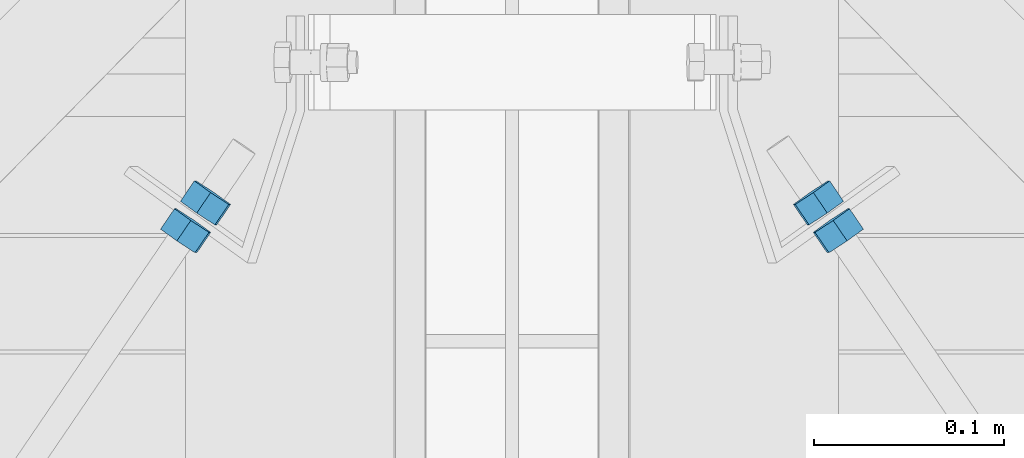
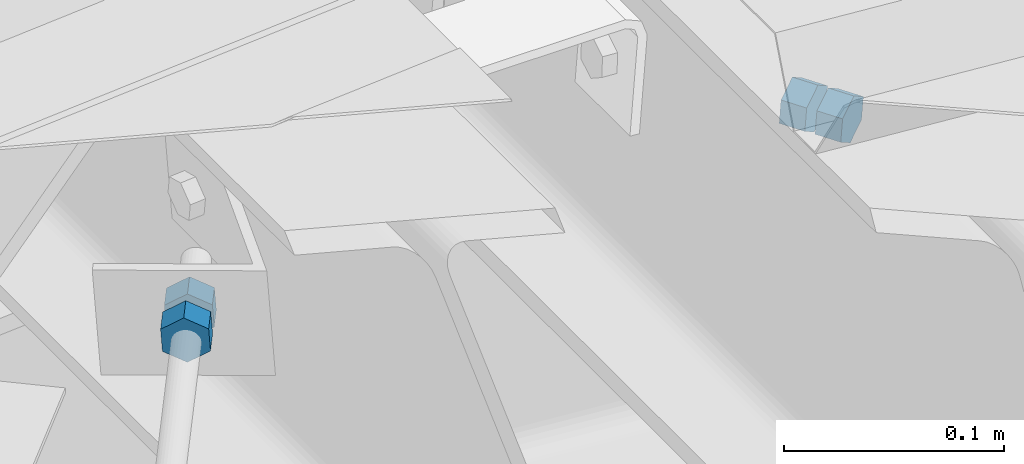
# One storey, part 26 of 70: 4 beams, 4 elements without a shape of their own.
"""IFC2X3 building model written with IfcOpenShell, lengths in millimetres."""

from ifc_helpers import new_model, si_unit, frame, origin_with_axes, place, context, subcontext, project, spatial, polyline, outline, extrude, material, type_object, element, aggregate, save


model = new_model("IFC2X3")

# Units and contexts
model_context = context("Model", 3, precision=1e-05, world=origin_with_axes())
body_context = subcontext(model_context, "Body", "Model", "MODEL_VIEW")
ifc_project = project(units=[si_unit("LENGTHUNIT", "METRE", prefix="MILLI"), si_unit("AREAUNIT", "SQUARE_METRE"), si_unit("VOLUMEUNIT", "CUBIC_METRE"), si_unit("MASSUNIT", "GRAM", prefix="KILO"), si_unit("TIMEUNIT", "SECOND"), si_unit("PLANEANGLEUNIT", "RADIAN"), si_unit("SOLIDANGLEUNIT", "STERADIAN"), si_unit("THERMODYNAMICTEMPERATUREUNIT", "DEGREE_CELSIUS"), si_unit("LUMINOUSINTENSITYUNIT", "LUMEN")], contexts=[model_context])

# Site, building, storey
site_placement = place(None, origin_with_axes())
site = spatial("IfcSite", under=ifc_project, at=site_placement, CompositionType="ELEMENT")
building_placement = place(site_placement, origin_with_axes())
building = spatial("IfcBuilding", under=site, at=building_placement, Name="Undefined", CompositionType="ELEMENT")
storey_placement = place(building_placement, origin_with_axes())
storey = spatial("IfcBuildingStorey", under=building, at=storey_placement, Name="Undefined", CompositionType="ELEMENT", Elevation=0.0)

# Assembly, beam
assembly_1_placement = place(storey_placement, origin_with_axes())
assembly_1 = element("IfcElementAssembly", 1, at=assembly_1_placement, inside=storey, Name="Steel Assembly", AssemblyPlace="NOTDEFINED", PredefinedType="RIGID_FRAME")
ifc_material = material(Name="STEEL/S235JR")
beam_type = type_object("IfcBeamType", Name="M14", PredefinedType="NOTDEFINED")
beam_1_placement = place(assembly_1_placement, frame((6667.89591440817, 11763.4629953896, 5197.40989395115), z_axis=(-0.823334618986936, -0.564011508365624, 0.0633334319989954), x_axis=(0.562350226933823, -0.825766911902794, -0.0432577099948882)))
beam_1 = element("IfcBeam", 2, at=beam_1_placement, type_object=beam_type, material=ifc_material, Name="M14", ObjectType="M14", context=body_context, shape_type="SweptSolid", body=[
    extrude(outline(polyline([(12.7045926734972, 1.09139364212751e-11), (6.35229633673589, -11.002499999985), (-6.352296336775, -11.0024999999832), (-12.7045926735282, 1.36424205265939e-11), (-6.35229633676863, 11.0025000000087), (6.35229633674408, 11.0025000000069), (12.7045926734972, 1.09139364212751e-11)])), frame((13.0000000000422, -9.09404496152177e-13, 4.28476698567782e-16), z_axis=(-1.0, 0.0, 0.0), x_axis=(0.0, -1.0, 0.0)), (0.0, 0.0, 1.0), 13.0),
])
aggregate(assembly_1, [beam_1])

assembly_2_placement = place(storey_placement, origin_with_axes())
assembly_2 = element("IfcElementAssembly", 3, at=assembly_2_placement, inside=storey, Name="Steel Assembly", AssemblyPlace="NOTDEFINED", PredefinedType="RIGID_FRAME")
beam_2_placement = place(assembly_2_placement, frame((6657.46998747971, 11778.1141677896, 5198.21188833059), z_axis=(-0.823334618986936, -0.564011508365624, 0.0633334319989954), x_axis=(0.562350226933823, -0.825766911902794, -0.0432577099948882)))
beam_2 = element("IfcBeam", 4, at=beam_2_placement, type_object=beam_type, material=ifc_material, Name="M14", ObjectType="M14", context=body_context, shape_type="SweptSolid", body=[
    extrude(outline(polyline([(12.7045926734972, 1.09139364212751e-11), (6.35229633673589, -11.002499999985), (-6.352296336775, -11.0024999999832), (-12.7045926735282, 1.36424205265939e-11), (-6.35229633676863, 11.0025000000087), (6.35229633674408, 11.0025000000069), (12.7045926734972, 1.09139364212751e-11)])), frame((13.0000000000422, -9.09404496152177e-13, 4.28476698567782e-16), z_axis=(-1.0, 0.0, 0.0), x_axis=(0.0, -1.0, 0.0)), (0.0, 0.0, 1.0), 13.0),
])
aggregate(assembly_2, [beam_2])

assembly_3_placement = place(storey_placement, origin_with_axes())
assembly_3 = element("IfcElementAssembly", 5, at=assembly_3_placement, inside=storey, Name="Steel Assembly", AssemblyPlace="NOTDEFINED", PredefinedType="RIGID_FRAME")
beam_3_placement = place(assembly_3_placement, frame((6332.10408560018, 11763.4629953895, 5197.40989395091), z_axis=(0.823334618986981, -0.564011508365557, 0.063333431998999), x_axis=(-0.5623502269338, -0.825766911902807, -0.0432577099949295)))
beam_3 = element("IfcBeam", 6, at=beam_3_placement, type_object=beam_type, material=ifc_material, Name="M14", ObjectType="M14", context=body_context, shape_type="SweptSolid", body=[
    extrude(outline(polyline([(12.7045926734972, 1.09139364212751e-11), (6.35229633673589, -11.002499999985), (-6.352296336775, -11.0024999999832), (-12.7045926735282, 1.36424205265939e-11), (-6.35229633676863, 11.0025000000087), (6.35229633674408, 11.0025000000069), (12.7045926734972, 1.09139364212751e-11)])), frame((13.0000000000422, -9.09404496152177e-13, 4.28476698567782e-16), z_axis=(-1.0, 0.0, 0.0), x_axis=(0.0, -1.0, 0.0)), (0.0, 0.0, 1.0), 13.0),
])
aggregate(assembly_3, [beam_3])

assembly_4_placement = place(storey_placement, origin_with_axes())
assembly_4 = element("IfcElementAssembly", 7, at=assembly_4_placement, inside=storey, Name="Steel Assembly", AssemblyPlace="NOTDEFINED", PredefinedType="RIGID_FRAME")
beam_4_placement = place(assembly_4_placement, frame((6342.53001252864, 11778.1141677896, 5198.21188833037), z_axis=(0.823334618986981, -0.564011508365557, 0.063333431998999), x_axis=(-0.5623502269338, -0.825766911902807, -0.0432577099949295)))
beam_4 = element("IfcBeam", 8, at=beam_4_placement, type_object=beam_type, material=ifc_material, Name="M14", ObjectType="M14", context=body_context, shape_type="SweptSolid", body=[
    extrude(outline(polyline([(12.7045926734972, 1.09139364212751e-11), (6.35229633673589, -11.002499999985), (-6.352296336775, -11.0024999999832), (-12.7045926735282, 1.36424205265939e-11), (-6.35229633676863, 11.0025000000087), (6.35229633674408, 11.0025000000069), (12.7045926734972, 1.09139364212751e-11)])), frame((13.0000000000422, -9.09404496152177e-13, 4.28476698567782e-16), z_axis=(-1.0, 0.0, 0.0), x_axis=(0.0, -1.0, 0.0)), (0.0, 0.0, 1.0), 13.0),
])
aggregate(assembly_4, [beam_4])

save(model, "model.ifc")
